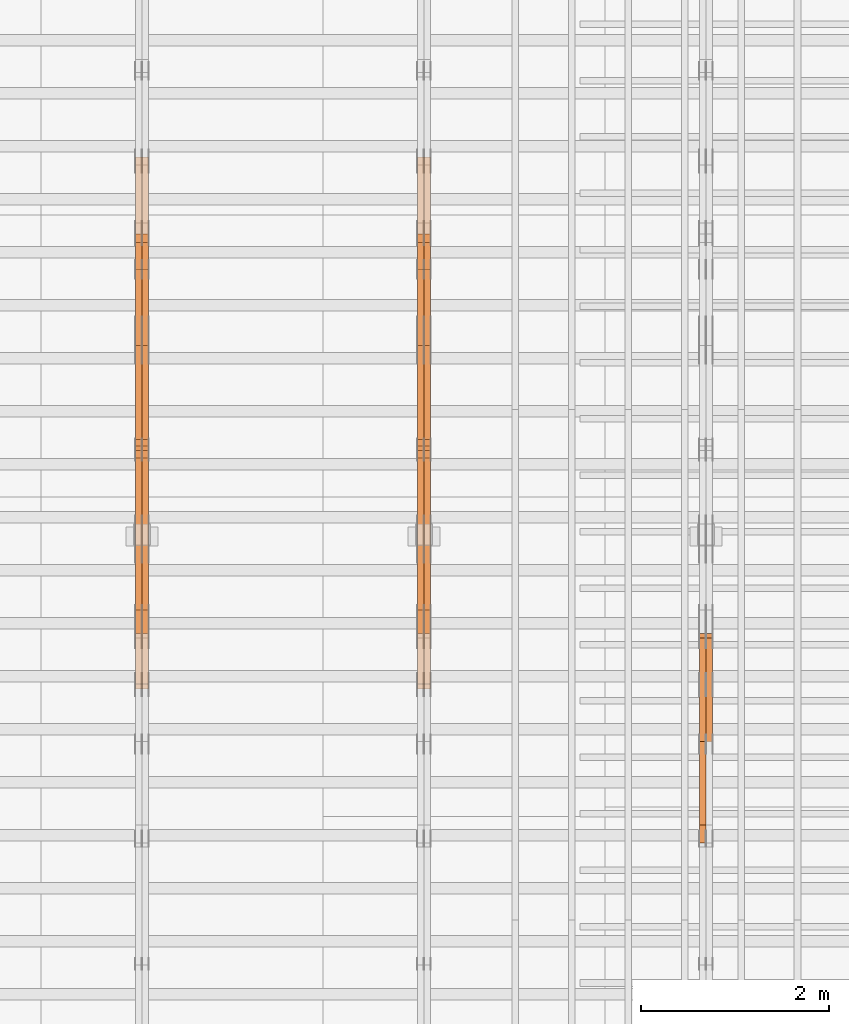
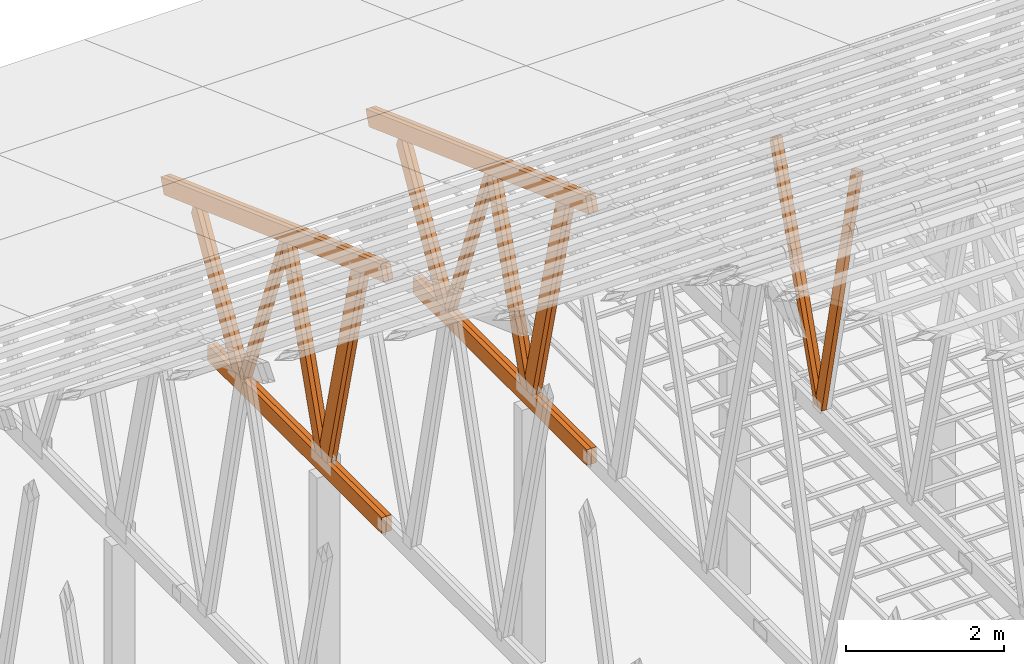
# One storey, part 60 of 189: 27 proxies.
"""IFC2X3 building model written with IfcOpenShell, lengths in millimetres."""

from ifc_helpers import new_model, entity, si_unit, converted_unit, derived_unit, direction, frame, origin, origin_2d_with_axis, place, context, subcontext, project, spatial, polyline, rectangle, outline, extrude, source, transform, mapped, material, type_object, type_shapes, element, save


model = new_model("IFC2X3")

# Units and contexts
model_context = context("Model", 3, precision=0.01, world=origin(), true_north=direction((6.12303176911189e-17, 1.0)))
body_context = subcontext(model_context, "Body", "Model", "MODEL_VIEW")
ifc_project = project(units=[si_unit("LENGTHUNIT", "METRE", prefix="MILLI"), si_unit("AREAUNIT", "SQUARE_METRE"), si_unit("VOLUMEUNIT", "CUBIC_METRE"), converted_unit("PLANEANGLEUNIT", "DEGREE", entity("IfcRatioMeasure", 0.0174532925199433), si_unit("PLANEANGLEUNIT", "RADIAN"), dimensions=[0, 0, 0, 0, 0, 0, 0]), si_unit("MASSUNIT", "GRAM", prefix="KILO"), derived_unit("MASSDENSITYUNIT", [(si_unit("MASSUNIT", "GRAM", prefix="KILO"), 1), (si_unit("LENGTHUNIT", "METRE"), -3)]), si_unit("TIMEUNIT", "SECOND"), si_unit("FREQUENCYUNIT", "HERTZ"), si_unit("THERMODYNAMICTEMPERATUREUNIT", "DEGREE_CELSIUS"), derived_unit("THERMALTRANSMITTANCEUNIT", [(si_unit("MASSUNIT", "GRAM", prefix="KILO"), 1), (si_unit("THERMODYNAMICTEMPERATUREUNIT", "KELVIN"), -1), (si_unit("TIMEUNIT", "SECOND"), -3)]), derived_unit("VOLUMETRICFLOWRATEUNIT", [(si_unit("LENGTHUNIT", "METRE"), 3), (si_unit("TIMEUNIT", "SECOND"), -1)]), si_unit("ELECTRICCURRENTUNIT", "AMPERE"), si_unit("ELECTRICVOLTAGEUNIT", "VOLT"), si_unit("POWERUNIT", "WATT"), si_unit("FORCEUNIT", "NEWTON"), si_unit("ILLUMINANCEUNIT", "LUX"), si_unit("LUMINOUSFLUXUNIT", "LUMEN"), si_unit("LUMINOUSINTENSITYUNIT", "CANDELA"), derived_unit("USERDEFINED", [(si_unit("MASSUNIT", "GRAM", prefix="KILO"), -1), (si_unit("LENGTHUNIT", "METRE"), -2), (si_unit("TIMEUNIT", "SECOND"), 3), (si_unit("LUMINOUSFLUXUNIT", "LUMEN"), 1)]), derived_unit("LINEARVELOCITYUNIT", [(si_unit("LENGTHUNIT", "METRE"), 1), (si_unit("TIMEUNIT", "SECOND"), -1)]), si_unit("PRESSUREUNIT", "PASCAL"), derived_unit("USERDEFINED", [(si_unit("LENGTHUNIT", "METRE"), -2), (si_unit("MASSUNIT", "GRAM", prefix="KILO"), 1), (si_unit("TIMEUNIT", "SECOND"), -2)])], contexts=[model_context])

# Site, building, storey
site_placement = place(None, origin())
site = spatial("IfcSite", under=ifc_project, at=site_placement, CompositionType="ELEMENT")
building_placement = place(site_placement, origin())
building = spatial("IfcBuilding", under=site, at=building_placement, CompositionType="ELEMENT")
storey_placement = place(building_placement, origin())
storey = spatial("IfcBuildingStorey", under=building, at=storey_placement, Name="Default", CompositionType="ELEMENT", Elevation=0.0)

# Proxies
ifc_material_1 = material(Name="IfcSurfaceStyle #241598")
building_element_proxy_type_1 = type_object("IfcBuildingElementProxyType", Name="T1-W3 241596", PredefinedType="NOTDEFINED", material=ifc_material_1)
shared_shape_1 = source(origin(), body_context, "Body", "SweptSolid", [
    extrude(outline(polyline([(-2517.58938959787, -85.0001104675026), (1625.445846867, -85.0001104675027), (1768.20563426494, 0.000209440697654673), (1749.48871563991, 85.0000057471538), (-2625.55080717397, 85.0000057471538), (-2517.58938959787, -85.0001104675026)])), frame((1768.2056683344, 85.0000547211315, 0.0), z_axis=(0.0, 0.0, 1.0), x_axis=(-1.0, 0.0, 0.0)), (0.0, 0.0, 1.0), 69.9999999999997),
])
type_shapes(building_element_proxy_type_1, [shared_shape_1])
proxy_1_placement = place(building_placement, frame((45230.0, 18415.3042863408, 226.720947016584), z_axis=(-1.0, 0.0, 0.0), x_axis=(0.0, -0.215047682154604, 0.976603550269982)))
element("IfcBuildingElementProxy", 1, at=proxy_1_placement, inside=storey, type_object=building_element_proxy_type_1, material=ifc_material_1, Name="T1-W3", context=body_context, shape_type="MappedRepresentation", body=[
    mapped(shared_shape_1, transform((0.0, 0.0, 0.0), scale=1.0)),
])
ifc_material_2 = material(Name="IfcSurfaceStyle #241400")
building_element_proxy_type_2 = type_object("IfcBuildingElementProxyType", Name="T1-W7 241398", PredefinedType="NOTDEFINED", material=ifc_material_2)
shared_shape_2 = source(origin(), body_context, "Body", "SweptSolid", [
    extrude(outline(polyline([(-2189.6662270939, -47.5000140805343), (1475.30081553583, -47.5000140805343), (1473.93388518462, 0.00042343352179337), (1398.58463533215, 47.4998023637734), (-2158.15310895869, 47.4998023637734), (-2189.6662270939, -47.5000140805343)])), frame((1475.30081553583, 47.5004895824757, 0.0), z_axis=(0.0, 0.0, 1.0), x_axis=(-1.0, 0.0, 0.0)), (0.0, 0.0, 1.0), 69.9999999999998),
])
type_shapes(building_element_proxy_type_2, [shared_shape_2])
proxy_2_placement = place(building_placement, frame((45300.0, 19742.3819153401, 3693.66743808885), z_axis=(-1.0, 0.0, 0.0), x_axis=(0.0, -0.314845237923104, -0.949143021971475)))
element("IfcBuildingElementProxy", 2, at=proxy_2_placement, inside=storey, type_object=building_element_proxy_type_2, material=ifc_material_2, Name="T1-W7", context=body_context, shape_type="MappedRepresentation", body=[
    mapped(shared_shape_2, transform((0.0, 0.0, 0.0), scale=1.0)),
])
ifc_material_3 = material(Name="IfcSurfaceStyle #241334")
building_element_proxy_type_3 = type_object("IfcBuildingElementProxyType", Name="T1-W7 241332", PredefinedType="NOTDEFINED", material=ifc_material_3)
shared_shape_3 = source(origin(), body_context, "Body", "SweptSolid", [
    extrude(outline(polyline([(-2189.6662270939, -47.5000140805343), (1475.30081553583, -47.5000140805343), (1473.93388518462, 0.00042343352179337), (1398.58463533215, 47.4998023637734), (-2158.15310895869, 47.4998023637734), (-2189.6662270939, -47.5000140805343)])), frame((1475.30081553583, 47.5004895824757, 0.0), z_axis=(0.0, 0.0, 1.0), x_axis=(-1.0, 0.0, 0.0)), (0.0, 0.0, 1.0), 69.9999999999998),
])
type_shapes(building_element_proxy_type_3, [shared_shape_3])
proxy_3_placement = place(building_placement, frame((45230.0, 19742.3819153401, 3693.66743808885), z_axis=(-1.0, 0.0, 0.0), x_axis=(0.0, -0.314845237923104, -0.949143021971475)))
element("IfcBuildingElementProxy", 3, at=proxy_3_placement, inside=storey, type_object=building_element_proxy_type_3, material=ifc_material_3, Name="T1-W7", context=body_context, shape_type="MappedRepresentation", body=[
    mapped(shared_shape_3, transform((0.0, 0.0, 0.0), scale=1.0)),
])
ifc_material_4 = material(Name="IfcSurfaceStyle #225346")
building_element_proxy_type_4 = type_object("IfcBuildingElementProxyType", Name="T1-W1 225344", PredefinedType="NOTDEFINED", material=ifc_material_4)
shared_shape_4 = source(origin(), body_context, "Body", "SweptSolid", [
    extrude(outline(polyline([(-1996.99427801396, -109.999889649051), (1271.09905152223, -109.999889649051), (1448.88120817726, -0.000113190727324008), (1421.70802776002, 109.999946244415), (-2144.69400944554, 109.999946244415), (-1996.99427801396, -109.999889649051)])), frame((1448.88120817726, 110.000265670598, 0.0), z_axis=(0.0, 0.0, 1.0), x_axis=(-1.0, 0.0, 0.0)), (0.0, 0.0, 1.0), 69.9999999999998),
])
type_shapes(building_element_proxy_type_4, [shared_shape_4])
proxy_4_placement = place(building_placement, frame((42300.0, 20558.6774904859, 218.61972674968), z_axis=(-1.0, 0.0, 0.0), x_axis=(0.0, -0.239819839925979, 0.970817410421691)))
element("IfcBuildingElementProxy", 4, at=proxy_4_placement, inside=storey, type_object=building_element_proxy_type_4, material=ifc_material_4, Name="T1-W1", context=body_context, shape_type="MappedRepresentation", body=[
    mapped(shared_shape_4, transform((0.0, 0.0, 0.0), scale=1.0)),
])
ifc_material_5 = material(Name="IfcSurfaceStyle #225280")
building_element_proxy_type_5 = type_object("IfcBuildingElementProxyType", Name="T1-W1 225278", PredefinedType="NOTDEFINED", material=ifc_material_5)
shared_shape_5 = source(origin(), body_context, "Body", "SweptSolid", [
    extrude(outline(polyline([(-1996.99427801396, -109.999889649051), (1271.09905152223, -109.999889649051), (1448.88120817726, -0.000113190727324008), (1421.70802776002, 109.999946244415), (-2144.69400944554, 109.999946244415), (-1996.99427801396, -109.999889649051)])), frame((1448.88120817726, 110.000265670598, 0.0), z_axis=(0.0, 0.0, 1.0), x_axis=(-1.0, 0.0, 0.0)), (0.0, 0.0, 1.0), 69.9999999999998),
])
type_shapes(building_element_proxy_type_5, [shared_shape_5])
proxy_5_placement = place(building_placement, frame((42230.0, 20558.6774904859, 218.61972674968), z_axis=(-1.0, 0.0, 0.0), x_axis=(0.0, -0.239819839925979, 0.970817410421691)))
element("IfcBuildingElementProxy", 5, at=proxy_5_placement, inside=storey, type_object=building_element_proxy_type_5, material=ifc_material_5, Name="T1-W1", context=body_context, shape_type="MappedRepresentation", body=[
    mapped(shared_shape_5, transform((0.0, 0.0, 0.0), scale=1.0)),
])
ifc_material_6 = material(Name="IfcSurfaceStyle #225082")
building_element_proxy_type_6 = type_object("IfcBuildingElementProxyType", Name="T1-W4 225080", PredefinedType="NOTDEFINED", material=ifc_material_6)
shared_shape_6 = source(origin(), body_context, "Body", "SweptSolid", [
    extrude(outline(polyline([(-1742.90513395849, -84.9997422414737), (1181.3544167489, -84.9997422414737), (1178.19398821251, -0.000208932978430543), (1071.44989130457, 84.999846707963), (-1688.09316230749, 84.999846707963), (-1742.90513395849, -84.9997422414737)])), frame((1181.35452116422, 84.999886337523, 0.0), z_axis=(0.0, 0.0, 1.0), x_axis=(-1.0, 0.0, 0.0)), (0.0, 0.0, 1.0), 69.9999999999998),
])
type_shapes(building_element_proxy_type_6, [shared_shape_6])
proxy_6_placement = place(building_placement, frame((42300.0, 21724.6281517871, 2976.00232464744), z_axis=(-1.0, 0.0, 0.0), x_axis=(0.0, -0.306868406216495, -0.951751953644514)))
element("IfcBuildingElementProxy", 6, at=proxy_6_placement, inside=storey, type_object=building_element_proxy_type_6, material=ifc_material_6, Name="T1-W4", context=body_context, shape_type="MappedRepresentation", body=[
    mapped(shared_shape_6, transform((0.0, 0.0, 0.0), scale=1.0)),
])
ifc_material_7 = material(Name="IfcSurfaceStyle #225016")
building_element_proxy_type_7 = type_object("IfcBuildingElementProxyType", Name="T1-W4 225014", PredefinedType="NOTDEFINED", material=ifc_material_7)
shared_shape_7 = source(origin(), body_context, "Body", "SweptSolid", [
    extrude(outline(polyline([(-1742.90513395849, -84.9997422414737), (1181.3544167489, -84.9997422414737), (1178.19398821251, -0.000208932978430543), (1071.44989130457, 84.999846707963), (-1688.09316230749, 84.999846707963), (-1742.90513395849, -84.9997422414737)])), frame((1181.35452116422, 84.999886337523, 0.0), z_axis=(0.0, 0.0, 1.0), x_axis=(-1.0, 0.0, 0.0)), (0.0, 0.0, 1.0), 69.9999999999998),
])
type_shapes(building_element_proxy_type_7, [shared_shape_7])
proxy_7_placement = place(building_placement, frame((42230.0, 21724.6281517871, 2976.00232464744), z_axis=(-1.0, 0.0, 0.0), x_axis=(0.0, -0.306868406216495, -0.951751953644514)))
element("IfcBuildingElementProxy", 7, at=proxy_7_placement, inside=storey, type_object=building_element_proxy_type_7, material=ifc_material_7, Name="T1-W4", context=body_context, shape_type="MappedRepresentation", body=[
    mapped(shared_shape_7, transform((0.0, 0.0, 0.0), scale=1.0)),
])
ifc_material_8 = material(Name="IfcSurfaceStyle #224818")
building_element_proxy_type_8 = type_object("IfcBuildingElementProxyType", Name="T1-W8 224816", PredefinedType="NOTDEFINED", material=ifc_material_8)
shared_shape_8 = source(origin(), body_context, "Body", "SweptSolid", [
    extrude(outline(polyline([(-1700.10906247918, -47.4998559987011), (1140.60243146647, -47.4998559987011), (1179.56122089033, 0.000120838919977206), (1161.65086478184, 47.4997955792411), (-1781.70545465947, 47.4997955792411), (-1700.10906247918, -47.4998559987011)])), frame((1179.56128464708, 47.5000634692093, 0.0), z_axis=(0.0, 0.0, 1.0), x_axis=(-1.0, 0.0, 0.0)), (0.0, 0.0, 1.0), 69.9999999999998),
])
type_shapes(building_element_proxy_type_8, [shared_shape_8])
proxy_8_placement = place(building_placement, frame((42300.0, 22687.5385403115, 228.241249073207), z_axis=(-1.0, 0.0, 0.0), x_axis=(0.0, -0.352814979177604, 0.93569310698963)))
element("IfcBuildingElementProxy", 8, at=proxy_8_placement, inside=storey, type_object=building_element_proxy_type_8, material=ifc_material_8, Name="T1-W8", context=body_context, shape_type="MappedRepresentation", body=[
    mapped(shared_shape_8, transform((0.0, 0.0, 0.0), scale=1.0)),
])
ifc_material_9 = material(Name="IfcSurfaceStyle #224752")
building_element_proxy_type_9 = type_object("IfcBuildingElementProxyType", Name="T1-W8 224750", PredefinedType="NOTDEFINED", material=ifc_material_9)
shared_shape_9 = source(origin(), body_context, "Body", "SweptSolid", [
    extrude(outline(polyline([(-1700.10906247918, -47.4998559987011), (1140.60243146647, -47.4998559987011), (1179.56122089033, 0.000120838919977206), (1161.65086478184, 47.4997955792411), (-1781.70545465947, 47.4997955792411), (-1700.10906247918, -47.4998559987011)])), frame((1179.56128464708, 47.5000634692093, 0.0), z_axis=(0.0, 0.0, 1.0), x_axis=(-1.0, 0.0, 0.0)), (0.0, 0.0, 1.0), 69.9999999999998),
])
type_shapes(building_element_proxy_type_9, [shared_shape_9])
proxy_9_placement = place(building_placement, frame((42230.0, 22687.5385403115, 228.241249073207), z_axis=(-1.0, 0.0, 0.0), x_axis=(0.0, -0.352814979177604, 0.93569310698963)))
element("IfcBuildingElementProxy", 9, at=proxy_9_placement, inside=storey, type_object=building_element_proxy_type_9, material=ifc_material_9, Name="T1-W8", context=body_context, shape_type="MappedRepresentation", body=[
    mapped(shared_shape_9, transform((0.0, 0.0, 0.0), scale=1.0)),
])
ifc_material_10 = material(Name="IfcSurfaceStyle #224554")
building_element_proxy_type_10 = type_object("IfcBuildingElementProxyType", Name="T1-W2 224552", PredefinedType="NOTDEFINED", material=ifc_material_10)
shared_shape_10 = source(origin(), body_context, "Body", "SweptSolid", [
    extrude(outline(polyline([(-1361.89144606429, -97.5000598486876), (887.613245225805, -97.5000598486876), (904.774262962339, 0.000302345139042259), (818.892339969004, 97.4999086761182), (-1249.38840209286, 97.4999086761182), (-1361.89144606429, -97.5000598486876)])), frame((904.774262962339, 97.5000966763391, 0.0), z_axis=(0.0, 0.0, 1.0), x_axis=(-1.0, 0.0, 0.0)), (0.0, 0.0, 1.0), 69.9999999999999),
])
type_shapes(building_element_proxy_type_10, [shared_shape_10])
proxy_10_placement = place(building_placement, frame((42300.0, 24033.6159173732, 2110.89189244614), z_axis=(-1.0, 0.0, 0.0), x_axis=(0.0, -0.5, -0.866025403784439)))
element("IfcBuildingElementProxy", 10, at=proxy_10_placement, inside=storey, type_object=building_element_proxy_type_10, material=ifc_material_10, Name="T1-W2", context=body_context, shape_type="MappedRepresentation", body=[
    mapped(shared_shape_10, transform((0.0, 0.0, 0.0), scale=1.0)),
])
ifc_material_11 = material(Name="IfcSurfaceStyle #224488")
building_element_proxy_type_11 = type_object("IfcBuildingElementProxyType", Name="T1-W2 224486", PredefinedType="NOTDEFINED", material=ifc_material_11)
shared_shape_11 = source(origin(), body_context, "Body", "SweptSolid", [
    extrude(outline(polyline([(-1361.89144606429, -97.5000598486876), (887.613245225805, -97.5000598486876), (904.774262962339, 0.000302345139042259), (818.892339969004, 97.4999086761182), (-1249.38840209286, 97.4999086761182), (-1361.89144606429, -97.5000598486876)])), frame((904.774262962339, 97.5000966763391, 0.0), z_axis=(0.0, 0.0, 1.0), x_axis=(-1.0, 0.0, 0.0)), (0.0, 0.0, 1.0), 69.9999999999999),
])
type_shapes(building_element_proxy_type_11, [shared_shape_11])
proxy_11_placement = place(building_placement, frame((42230.0, 24033.6159173732, 2110.89189244614), z_axis=(-1.0, 0.0, 0.0), x_axis=(0.0, -0.5, -0.866025403784439)))
element("IfcBuildingElementProxy", 11, at=proxy_11_placement, inside=storey, type_object=building_element_proxy_type_11, material=ifc_material_11, Name="T1-W2", context=body_context, shape_type="MappedRepresentation", body=[
    mapped(shared_shape_11, transform((0.0, 0.0, 0.0), scale=1.0)),
])
ifc_material_12 = material(Name="IfcSurfaceStyle #222478")
building_element_proxy_type_12 = type_object("IfcBuildingElementProxyType", Name="T1-B4 222476", PredefinedType="NOTDEFINED", material=ifc_material_12)
shared_shape_12 = source(origin(), body_context, "Body", "SweptSolid", [
    extrude(rectangle(XDim=4408.2412109375, YDim=245.000000000001, at=origin_2d_with_axis()), frame((2204.12060546875, 122.5, 0.0), z_axis=(0.0, 0.0, 1.0), x_axis=(-1.0, 0.0, 0.0)), (0.0, 0.0, 1.0), 69.9999999999997),
])
type_shapes(building_element_proxy_type_12, [shared_shape_12])
proxy_12_placement = place(building_placement, frame((42300.0, 19161.7587890625, 245.0), z_axis=(-1.0, 0.0, 0.0), x_axis=(0.0, 1.0, 0.0)))
element("IfcBuildingElementProxy", 12, at=proxy_12_placement, inside=storey, type_object=building_element_proxy_type_12, material=ifc_material_12, Name="T1-B4", context=body_context, shape_type="MappedRepresentation", body=[
    mapped(shared_shape_12, transform((0.0, 0.0, 0.0), scale=1.0)),
])
ifc_material_13 = material(Name="IfcSurfaceStyle #222421")
building_element_proxy_type_13 = type_object("IfcBuildingElementProxyType", Name="T1-B4 222419", PredefinedType="NOTDEFINED", material=ifc_material_13)
shared_shape_13 = source(origin(), body_context, "Body", "SweptSolid", [
    extrude(rectangle(XDim=4408.2412109375, YDim=245.000000000001, at=origin_2d_with_axis()), frame((2204.12060546875, 122.5, 0.0), z_axis=(0.0, 0.0, 1.0), x_axis=(-1.0, 0.0, 0.0)), (0.0, 0.0, 1.0), 69.9999999999997),
])
type_shapes(building_element_proxy_type_13, [shared_shape_13])
proxy_13_placement = place(building_placement, frame((42230.0, 19161.7587890625, 245.0), z_axis=(-1.0, 0.0, 0.0), x_axis=(0.0, 1.0, 0.0)))
element("IfcBuildingElementProxy", 13, at=proxy_13_placement, inside=storey, type_object=building_element_proxy_type_13, material=ifc_material_13, Name="T1-B4", context=body_context, shape_type="MappedRepresentation", body=[
    mapped(shared_shape_13, transform((0.0, 0.0, 0.0), scale=1.0)),
])
ifc_material_14 = material(Name="IfcSurfaceStyle #221434")
building_element_proxy_type_14 = type_object("IfcBuildingElementProxyType", Name="T1-T1 221432", PredefinedType="NOTDEFINED", material=ifc_material_14)
shared_shape_14 = source(origin(), body_context, "Body", "SweptSolid", [
    extrude(outline(polyline([(-2964.99982426074, -122.499947708046), (2964.99981923522, -122.499947708046), (2964.99984513599, 122.499947708046), (-2964.99984011047, 122.499947708046), (-2964.99982426074, -122.499947708046)])), frame((2964.99984513599, 122.499998966405, 0.0), z_axis=(0.0, 0.0, 1.0), x_axis=(-1.0, 0.0, 0.0)), (0.0, 0.0, 1.0), 69.9999999999996),
])
type_shapes(building_element_proxy_type_14, [shared_shape_14])
proxy_14_placement = place(building_placement, frame((42300.0, 24681.3398262186, 1893.12531804384), z_axis=(-1.0, 0.0, 0.0), x_axis=(0.0, -0.939692620785908, 0.342020143325669)))
element("IfcBuildingElementProxy", 14, at=proxy_14_placement, inside=storey, type_object=building_element_proxy_type_14, material=ifc_material_14, Name="T1-T1", context=body_context, shape_type="MappedRepresentation", body=[
    mapped(shared_shape_14, transform((0.0, 0.0, 0.0), scale=1.0)),
])
ifc_material_15 = material(Name="IfcSurfaceStyle #221377")
building_element_proxy_type_15 = type_object("IfcBuildingElementProxyType", Name="T1-T1 221375", PredefinedType="NOTDEFINED", material=ifc_material_15)
shared_shape_15 = source(origin(), body_context, "Body", "SweptSolid", [
    extrude(outline(polyline([(-2964.99982426074, -122.499947708046), (2964.99981923522, -122.499947708046), (2964.99984513599, 122.499947708046), (-2964.99984011047, 122.499947708046), (-2964.99982426074, -122.499947708046)])), frame((2964.99984513599, 122.499998966405, 0.0), z_axis=(0.0, 0.0, 1.0), x_axis=(-1.0, 0.0, 0.0)), (0.0, 0.0, 1.0), 69.9999999999996),
])
type_shapes(building_element_proxy_type_15, [shared_shape_15])
proxy_15_placement = place(building_placement, frame((42230.0, 24681.3398262186, 1893.12531804384), z_axis=(-1.0, 0.0, 0.0), x_axis=(0.0, -0.939692620785908, 0.342020143325669)))
element("IfcBuildingElementProxy", 15, at=proxy_15_placement, inside=storey, type_object=building_element_proxy_type_15, material=ifc_material_15, Name="T1-T1", context=body_context, shape_type="MappedRepresentation", body=[
    mapped(shared_shape_15, transform((0.0, 0.0, 0.0), scale=1.0)),
])
ifc_material_16 = material(Name="IfcSurfaceStyle #209556")
building_element_proxy_type_16 = type_object("IfcBuildingElementProxyType", Name="T1-W1 209554", PredefinedType="NOTDEFINED", material=ifc_material_16)
shared_shape_16 = source(origin(), body_context, "Body", "SweptSolid", [
    extrude(outline(polyline([(-1996.99427801396, -109.999889649051), (1271.09905152223, -109.999889649051), (1448.88120817726, -0.000113190727324008), (1421.70802776002, 109.999946244415), (-2144.69400944554, 109.999946244415), (-1996.99427801396, -109.999889649051)])), frame((1448.88120817726, 110.000265670598, 0.0), z_axis=(0.0, 0.0, 1.0), x_axis=(-1.0, 0.0, 0.0)), (0.0, 0.0, 1.0), 69.9999999999998),
])
type_shapes(building_element_proxy_type_16, [shared_shape_16])
proxy_16_placement = place(building_placement, frame((39300.0, 20558.6774904859, 218.61972674968), z_axis=(-1.0, 0.0, 0.0), x_axis=(0.0, -0.239819839925979, 0.970817410421691)))
element("IfcBuildingElementProxy", 16, at=proxy_16_placement, inside=storey, type_object=building_element_proxy_type_16, material=ifc_material_16, Name="T1-W1", context=body_context, shape_type="MappedRepresentation", body=[
    mapped(shared_shape_16, transform((0.0, 0.0, 0.0), scale=1.0)),
])
ifc_material_17 = material(Name="IfcSurfaceStyle #209490")
building_element_proxy_type_17 = type_object("IfcBuildingElementProxyType", Name="T1-W1 209488", PredefinedType="NOTDEFINED", material=ifc_material_17)
shared_shape_17 = source(origin(), body_context, "Body", "SweptSolid", [
    extrude(outline(polyline([(-1996.99427801396, -109.999889649051), (1271.09905152223, -109.999889649051), (1448.88120817726, -0.000113190727324008), (1421.70802776002, 109.999946244415), (-2144.69400944554, 109.999946244415), (-1996.99427801396, -109.999889649051)])), frame((1448.88120817726, 110.000265670598, 0.0), z_axis=(0.0, 0.0, 1.0), x_axis=(-1.0, 0.0, 0.0)), (0.0, 0.0, 1.0), 69.9999999999998),
])
type_shapes(building_element_proxy_type_17, [shared_shape_17])
proxy_17_placement = place(building_placement, frame((39230.0, 20558.6774904859, 218.61972674968), z_axis=(-1.0, 0.0, 0.0), x_axis=(0.0, -0.239819839925979, 0.970817410421691)))
element("IfcBuildingElementProxy", 17, at=proxy_17_placement, inside=storey, type_object=building_element_proxy_type_17, material=ifc_material_17, Name="T1-W1", context=body_context, shape_type="MappedRepresentation", body=[
    mapped(shared_shape_17, transform((0.0, 0.0, 0.0), scale=1.0)),
])
ifc_material_18 = material(Name="IfcSurfaceStyle #209292")
building_element_proxy_type_18 = type_object("IfcBuildingElementProxyType", Name="T1-W4 209290", PredefinedType="NOTDEFINED", material=ifc_material_18)
shared_shape_18 = source(origin(), body_context, "Body", "SweptSolid", [
    extrude(outline(polyline([(-1742.90513395849, -84.9997422414737), (1181.3544167489, -84.9997422414737), (1178.19398821251, -0.000208932978430543), (1071.44989130457, 84.999846707963), (-1688.09316230749, 84.999846707963), (-1742.90513395849, -84.9997422414737)])), frame((1181.35452116422, 84.999886337523, 0.0), z_axis=(0.0, 0.0, 1.0), x_axis=(-1.0, 0.0, 0.0)), (0.0, 0.0, 1.0), 69.9999999999998),
])
type_shapes(building_element_proxy_type_18, [shared_shape_18])
proxy_18_placement = place(building_placement, frame((39300.0, 21724.6281517871, 2976.00232464744), z_axis=(-1.0, 0.0, 0.0), x_axis=(0.0, -0.306868406216495, -0.951751953644514)))
element("IfcBuildingElementProxy", 18, at=proxy_18_placement, inside=storey, type_object=building_element_proxy_type_18, material=ifc_material_18, Name="T1-W4", context=body_context, shape_type="MappedRepresentation", body=[
    mapped(shared_shape_18, transform((0.0, 0.0, 0.0), scale=1.0)),
])
ifc_material_19 = material(Name="IfcSurfaceStyle #209226")
building_element_proxy_type_19 = type_object("IfcBuildingElementProxyType", Name="T1-W4 209224", PredefinedType="NOTDEFINED", material=ifc_material_19)
shared_shape_19 = source(origin(), body_context, "Body", "SweptSolid", [
    extrude(outline(polyline([(-1742.90513395849, -84.9997422414737), (1181.3544167489, -84.9997422414737), (1178.19398821251, -0.000208932978430543), (1071.44989130457, 84.999846707963), (-1688.09316230749, 84.999846707963), (-1742.90513395849, -84.9997422414737)])), frame((1181.35452116422, 84.999886337523, 0.0), z_axis=(0.0, 0.0, 1.0), x_axis=(-1.0, 0.0, 0.0)), (0.0, 0.0, 1.0), 69.9999999999998),
])
type_shapes(building_element_proxy_type_19, [shared_shape_19])
proxy_19_placement = place(building_placement, frame((39230.0, 21724.6281517871, 2976.00232464744), z_axis=(-1.0, 0.0, 0.0), x_axis=(0.0, -0.306868406216495, -0.951751953644514)))
element("IfcBuildingElementProxy", 19, at=proxy_19_placement, inside=storey, type_object=building_element_proxy_type_19, material=ifc_material_19, Name="T1-W4", context=body_context, shape_type="MappedRepresentation", body=[
    mapped(shared_shape_19, transform((0.0, 0.0, 0.0), scale=1.0)),
])
ifc_material_20 = material(Name="IfcSurfaceStyle #209028")
building_element_proxy_type_20 = type_object("IfcBuildingElementProxyType", Name="T1-W8 209026", PredefinedType="NOTDEFINED", material=ifc_material_20)
shared_shape_20 = source(origin(), body_context, "Body", "SweptSolid", [
    extrude(outline(polyline([(-1700.10906247918, -47.4998559987011), (1140.60243146647, -47.4998559987011), (1179.56122089033, 0.000120838919977206), (1161.65086478184, 47.4997955792411), (-1781.70545465947, 47.4997955792411), (-1700.10906247918, -47.4998559987011)])), frame((1179.56128464708, 47.5000634692093, 0.0), z_axis=(0.0, 0.0, 1.0), x_axis=(-1.0, 0.0, 0.0)), (0.0, 0.0, 1.0), 69.9999999999998),
])
type_shapes(building_element_proxy_type_20, [shared_shape_20])
proxy_20_placement = place(building_placement, frame((39300.0, 22687.5385403115, 228.241249073207), z_axis=(-1.0, 0.0, 0.0), x_axis=(0.0, -0.352814979177604, 0.93569310698963)))
element("IfcBuildingElementProxy", 20, at=proxy_20_placement, inside=storey, type_object=building_element_proxy_type_20, material=ifc_material_20, Name="T1-W8", context=body_context, shape_type="MappedRepresentation", body=[
    mapped(shared_shape_20, transform((0.0, 0.0, 0.0), scale=1.0)),
])
ifc_material_21 = material(Name="IfcSurfaceStyle #208962")
building_element_proxy_type_21 = type_object("IfcBuildingElementProxyType", Name="T1-W8 208960", PredefinedType="NOTDEFINED", material=ifc_material_21)
shared_shape_21 = source(origin(), body_context, "Body", "SweptSolid", [
    extrude(outline(polyline([(-1700.10906247918, -47.4998559987011), (1140.60243146647, -47.4998559987011), (1179.56122089033, 0.000120838919977206), (1161.65086478184, 47.4997955792411), (-1781.70545465947, 47.4997955792411), (-1700.10906247918, -47.4998559987011)])), frame((1179.56128464708, 47.5000634692093, 0.0), z_axis=(0.0, 0.0, 1.0), x_axis=(-1.0, 0.0, 0.0)), (0.0, 0.0, 1.0), 69.9999999999998),
])
type_shapes(building_element_proxy_type_21, [shared_shape_21])
proxy_21_placement = place(building_placement, frame((39230.0, 22687.5385403115, 228.241249073207), z_axis=(-1.0, 0.0, 0.0), x_axis=(0.0, -0.352814979177604, 0.93569310698963)))
element("IfcBuildingElementProxy", 21, at=proxy_21_placement, inside=storey, type_object=building_element_proxy_type_21, material=ifc_material_21, Name="T1-W8", context=body_context, shape_type="MappedRepresentation", body=[
    mapped(shared_shape_21, transform((0.0, 0.0, 0.0), scale=1.0)),
])
ifc_material_22 = material(Name="IfcSurfaceStyle #208764")
building_element_proxy_type_22 = type_object("IfcBuildingElementProxyType", Name="T1-W2 208762", PredefinedType="NOTDEFINED", material=ifc_material_22)
shared_shape_22 = source(origin(), body_context, "Body", "SweptSolid", [
    extrude(outline(polyline([(-1361.89144606429, -97.5000598486876), (887.613245225805, -97.5000598486876), (904.774262962339, 0.000302345139042259), (818.892339969004, 97.4999086761182), (-1249.38840209286, 97.4999086761182), (-1361.89144606429, -97.5000598486876)])), frame((904.774262962339, 97.5000966763391, 0.0), z_axis=(0.0, 0.0, 1.0), x_axis=(-1.0, 0.0, 0.0)), (0.0, 0.0, 1.0), 69.9999999999999),
])
type_shapes(building_element_proxy_type_22, [shared_shape_22])
proxy_22_placement = place(building_placement, frame((39300.0, 24033.6159173732, 2110.89189244614), z_axis=(-1.0, 0.0, 0.0), x_axis=(0.0, -0.5, -0.866025403784439)))
element("IfcBuildingElementProxy", 22, at=proxy_22_placement, inside=storey, type_object=building_element_proxy_type_22, material=ifc_material_22, Name="T1-W2", context=body_context, shape_type="MappedRepresentation", body=[
    mapped(shared_shape_22, transform((0.0, 0.0, 0.0), scale=1.0)),
])
ifc_material_23 = material(Name="IfcSurfaceStyle #208698")
building_element_proxy_type_23 = type_object("IfcBuildingElementProxyType", Name="T1-W2 208696", PredefinedType="NOTDEFINED", material=ifc_material_23)
shared_shape_23 = source(origin(), body_context, "Body", "SweptSolid", [
    extrude(outline(polyline([(-1361.89144606429, -97.5000598486876), (887.613245225805, -97.5000598486876), (904.774262962339, 0.000302345139042259), (818.892339969004, 97.4999086761182), (-1249.38840209286, 97.4999086761182), (-1361.89144606429, -97.5000598486876)])), frame((904.774262962339, 97.5000966763391, 0.0), z_axis=(0.0, 0.0, 1.0), x_axis=(-1.0, 0.0, 0.0)), (0.0, 0.0, 1.0), 69.9999999999999),
])
type_shapes(building_element_proxy_type_23, [shared_shape_23])
proxy_23_placement = place(building_placement, frame((39230.0, 24033.6159173732, 2110.89189244614), z_axis=(-1.0, 0.0, 0.0), x_axis=(0.0, -0.5, -0.866025403784439)))
element("IfcBuildingElementProxy", 23, at=proxy_23_placement, inside=storey, type_object=building_element_proxy_type_23, material=ifc_material_23, Name="T1-W2", context=body_context, shape_type="MappedRepresentation", body=[
    mapped(shared_shape_23, transform((0.0, 0.0, 0.0), scale=1.0)),
])
ifc_material_24 = material(Name="IfcSurfaceStyle #206688")
building_element_proxy_type_24 = type_object("IfcBuildingElementProxyType", Name="T1-B4 206686", PredefinedType="NOTDEFINED", material=ifc_material_24)
shared_shape_24 = source(origin(), body_context, "Body", "SweptSolid", [
    extrude(rectangle(XDim=4408.2412109375, YDim=245.000000000001, at=origin_2d_with_axis()), frame((2204.12060546875, 122.5, 0.0), z_axis=(0.0, 0.0, 1.0), x_axis=(-1.0, 0.0, 0.0)), (0.0, 0.0, 1.0), 69.9999999999997),
])
type_shapes(building_element_proxy_type_24, [shared_shape_24])
proxy_24_placement = place(building_placement, frame((39300.0, 19161.7587890625, 245.0), z_axis=(-1.0, 0.0, 0.0), x_axis=(0.0, 1.0, 0.0)))
element("IfcBuildingElementProxy", 24, at=proxy_24_placement, inside=storey, type_object=building_element_proxy_type_24, material=ifc_material_24, Name="T1-B4", context=body_context, shape_type="MappedRepresentation", body=[
    mapped(shared_shape_24, transform((0.0, 0.0, 0.0), scale=1.0)),
])
ifc_material_25 = material(Name="IfcSurfaceStyle #206631")
building_element_proxy_type_25 = type_object("IfcBuildingElementProxyType", Name="T1-B4 206629", PredefinedType="NOTDEFINED", material=ifc_material_25)
shared_shape_25 = source(origin(), body_context, "Body", "SweptSolid", [
    extrude(rectangle(XDim=4408.2412109375, YDim=245.000000000001, at=origin_2d_with_axis()), frame((2204.12060546875, 122.5, 0.0), z_axis=(0.0, 0.0, 1.0), x_axis=(-1.0, 0.0, 0.0)), (0.0, 0.0, 1.0), 69.9999999999997),
])
type_shapes(building_element_proxy_type_25, [shared_shape_25])
proxy_25_placement = place(building_placement, frame((39230.0, 19161.7587890625, 245.0), z_axis=(-1.0, 0.0, 0.0), x_axis=(0.0, 1.0, 0.0)))
element("IfcBuildingElementProxy", 25, at=proxy_25_placement, inside=storey, type_object=building_element_proxy_type_25, material=ifc_material_25, Name="T1-B4", context=body_context, shape_type="MappedRepresentation", body=[
    mapped(shared_shape_25, transform((0.0, 0.0, 0.0), scale=1.0)),
])
ifc_material_26 = material(Name="IfcSurfaceStyle #205644")
building_element_proxy_type_26 = type_object("IfcBuildingElementProxyType", Name="T1-T1 205642", PredefinedType="NOTDEFINED", material=ifc_material_26)
shared_shape_26 = source(origin(), body_context, "Body", "SweptSolid", [
    extrude(outline(polyline([(-2964.99982426074, -122.499947708046), (2964.99981923522, -122.499947708046), (2964.99984513599, 122.499947708046), (-2964.99984011047, 122.499947708046), (-2964.99982426074, -122.499947708046)])), frame((2964.99984513599, 122.499998966405, 0.0), z_axis=(0.0, 0.0, 1.0), x_axis=(-1.0, 0.0, 0.0)), (0.0, 0.0, 1.0), 69.9999999999996),
])
type_shapes(building_element_proxy_type_26, [shared_shape_26])
proxy_26_placement = place(building_placement, frame((39300.0, 24681.3398262186, 1893.12531804384), z_axis=(-1.0, 0.0, 0.0), x_axis=(0.0, -0.939692620785908, 0.342020143325669)))
element("IfcBuildingElementProxy", 26, at=proxy_26_placement, inside=storey, type_object=building_element_proxy_type_26, material=ifc_material_26, Name="T1-T1", context=body_context, shape_type="MappedRepresentation", body=[
    mapped(shared_shape_26, transform((0.0, 0.0, 0.0), scale=1.0)),
])
ifc_material_27 = material(Name="IfcSurfaceStyle #205587")
building_element_proxy_type_27 = type_object("IfcBuildingElementProxyType", Name="T1-T1 205585", PredefinedType="NOTDEFINED", material=ifc_material_27)
shared_shape_27 = source(origin(), body_context, "Body", "SweptSolid", [
    extrude(outline(polyline([(-2964.99982426074, -122.499947708046), (2964.99981923522, -122.499947708046), (2964.99984513599, 122.499947708046), (-2964.99984011047, 122.499947708046), (-2964.99982426074, -122.499947708046)])), frame((2964.99984513599, 122.499998966405, 0.0), z_axis=(0.0, 0.0, 1.0), x_axis=(-1.0, 0.0, 0.0)), (0.0, 0.0, 1.0), 69.9999999999996),
])
type_shapes(building_element_proxy_type_27, [shared_shape_27])
proxy_27_placement = place(building_placement, frame((39230.0, 24681.3398262186, 1893.12531804384), z_axis=(-1.0, 0.0, 0.0), x_axis=(0.0, -0.939692620785908, 0.342020143325669)))
element("IfcBuildingElementProxy", 27, at=proxy_27_placement, inside=storey, type_object=building_element_proxy_type_27, material=ifc_material_27, Name="T1-T1", context=body_context, shape_type="MappedRepresentation", body=[
    mapped(shared_shape_27, transform((0.0, 0.0, 0.0), scale=1.0)),
])

save(model, "model.ifc")
